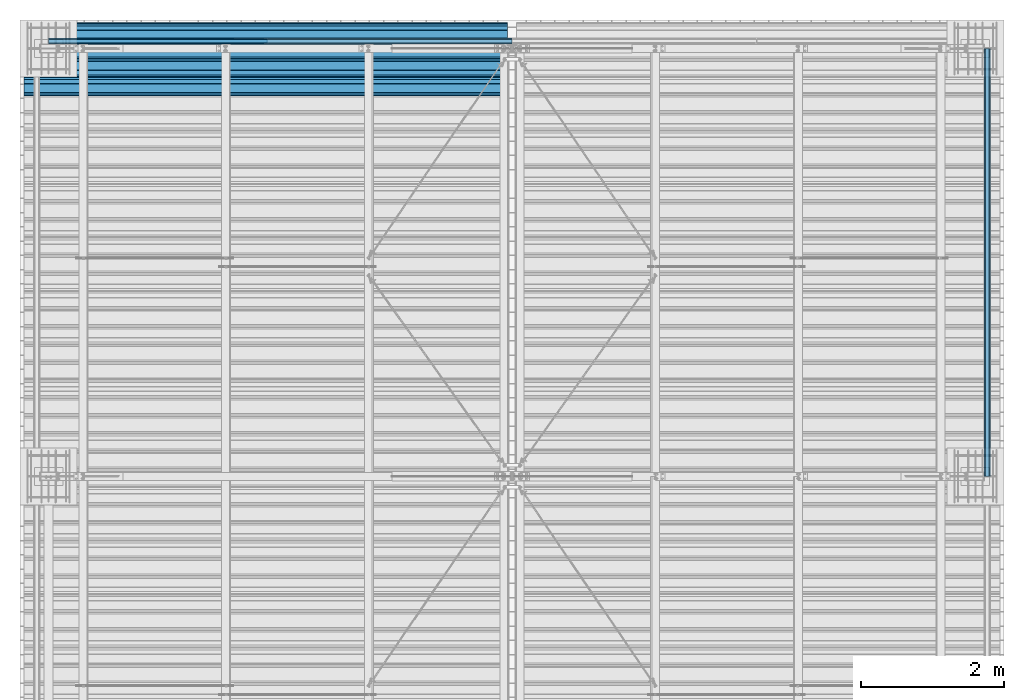
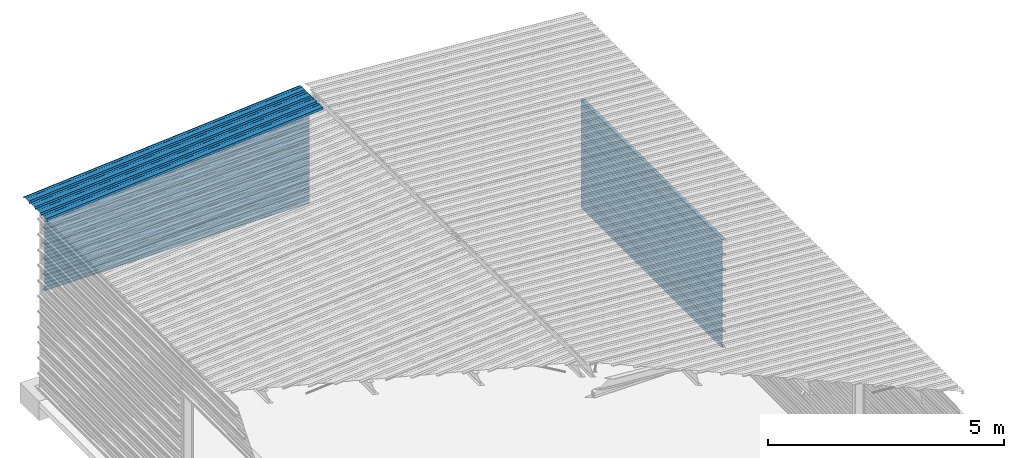
# One storey, part 19 of 70: 14 beams, 14 elements without a shape of their own.
"""IFC2X3 building model written with IfcOpenShell, lengths in millimetres."""

import ifcopenshell
import ifcopenshell.guid

model = None  # the IFC model being written
_history = None  # IfcOwnerHistory: only IFC2X3 demands one
_inside = {}  # id of a spatial element -> (the spatial element, [elements in it])
_under = {}  # id of a project, library or spatial element -> (it, [spatial elements below it])
_declared = {}  # id of a project -> (the project, [libraries it declares])
_typed = {}  # id of a type object -> (the type object, [elements of that type])
_made_of = {}  # id of a material, layer set ... -> (it, [elements and type objects made of it])


def new_model(schema):
    """Start an empty IFC model of exactly this schema.

    Asked for "IFC4X3", IfcOpenShell would pick the latest addendum, in which some entities
    have other attributes; the version numbers below select the first issue.
    IFC2X3 requires an IfcOwnerHistory on every rooted entity: one is made here for all.
    """
    global model, _history
    if schema == "IFC4X3":
        model = ifcopenshell.file(schema_version=(4, 3, 0, 0))
    else:
        model = ifcopenshell.file(schema=schema)
    _inside.clear()
    _under.clear()
    _declared.clear()
    _typed.clear()
    _made_of.clear()
    _history = None
    if model.schema == "IFC2X3":
        org = make("IfcOrganization", Name="unknown")
        user = make(
            "IfcPersonAndOrganization",
            ThePerson=make("IfcPerson", FamilyName="unknown"),
            TheOrganization=org,
        )
        app = make(
            "IfcApplication",
            ApplicationDeveloper=org,
            Version="unknown",
            ApplicationFullName="unknown",
            ApplicationIdentifier="unknown",
        )
        _history = make(
            "IfcOwnerHistory",
            OwningUser=user,
            OwningApplication=app,
            ChangeAction="ADDED",
            CreationDate=0,
        )
    return model


def make(cls, **values):
    """One entity of the class cls with the attributes given. An attribute that is None is left unset."""
    return model.create_entity(
        cls, **{name: value for name, value in values.items() if value is not None}
    )


def rooted(cls, **values):
    """An entity with a GlobalId (a new one), such as an element, a storey or a relation."""
    return make(cls, GlobalId=ifcopenshell.guid.new(), OwnerHistory=_history, **values)


def si_unit(unit_type, name, prefix=None):
    """IfcSIUnit, for example si_unit("LENGTHUNIT", "METRE", prefix="MILLI")."""
    return make("IfcSIUnit", UnitType=unit_type, Prefix=prefix, Name=name)


def assignment(units):
    """IfcUnitAssignment: the units of a project."""
    return None if units is None else make("IfcUnitAssignment", Units=units)


def point(xyz):
    """IfcCartesianPoint."""
    return None if xyz is None else make("IfcCartesianPoint", Coordinates=xyz)


def direction(xyz):
    """IfcDirection."""
    return None if xyz is None else make("IfcDirection", DirectionRatios=xyz)


def frame(location, z_axis=None, x_axis=None):
    """IfcAxis2Placement3D, a coordinate frame: its origin and axes. An axis left out is left unset."""
    return make(
        "IfcAxis2Placement3D",
        Location=point(location),
        Axis=direction(z_axis),
        RefDirection=direction(x_axis),
    )


def origin_with_axes():
    """The frame at (0, 0, 0) with the z axis (0, 0, 1) and the x axis (1, 0, 0) written out."""
    return frame((0.0, 0.0, 0.0), z_axis=(0.0, 0.0, 1.0), x_axis=(1.0, 0.0, 0.0))


def place(relative_to, where):
    """IfcLocalPlacement: puts the frame where relative to a parent placement (None: the world)."""
    return make(
        "IfcLocalPlacement", PlacementRelTo=relative_to, RelativePlacement=where
    )


def context(
    kind, dimensions, precision=None, world=None, true_north=None, identifier=None
):
    """IfcGeometricRepresentationContext, for example the 3D "Model" context."""
    return make(
        "IfcGeometricRepresentationContext",
        ContextIdentifier=identifier,
        ContextType=kind,
        CoordinateSpaceDimension=dimensions,
        Precision=precision,
        WorldCoordinateSystem=world,
        TrueNorth=true_north,
    )


def subcontext(parent, identifier, kind, view, scale=None):
    """IfcGeometricRepresentationSubContext, for example "Body" below "Model"."""
    return make(
        "IfcGeometricRepresentationSubContext",
        ContextIdentifier=identifier,
        ContextType=kind,
        ParentContext=parent,
        TargetScale=scale,
        TargetView=view,
    )


def project(units=None, contexts=None):
    """IfcProject with its units and contexts."""
    return rooted(
        "IfcProject",
        Name="project",
        RepresentationContexts=contexts,
        UnitsInContext=assignment(units),
    )


def spatial(cls, under=None, at=None, **own):
    """A site, building, storey or space (cls), placed at a placement, below another one or the project."""
    s = rooted(cls, ObjectPlacement=at, **own)
    if under is not None:
        _under.setdefault(under.id(), (under, []))[1].append(s)
    return s


def polyline(points):
    """IfcPolyline through the points."""
    return make("IfcPolyline", Points=[point(p) for p in points])


def outline(outer, holes=None, kind="AREA"):
    """IfcArbitraryClosedProfileDef: a profile drawn as a closed curve; with holes, ...WithVoids."""
    if holes is None:
        return make("IfcArbitraryClosedProfileDef", ProfileType=kind, OuterCurve=outer)
    return make(
        "IfcArbitraryProfileDefWithVoids",
        ProfileType=kind,
        OuterCurve=outer,
        InnerCurves=holes,
    )


def extrude(swept, where, along, depth):
    """IfcExtrudedAreaSolid: the profile swept, set in the frame where, extruded along a direction by depth."""
    return make(
        "IfcExtrudedAreaSolid",
        SweptArea=swept,
        Position=where,
        ExtrudedDirection=direction(along),
        Depth=depth,
    )


def clip(a, b, op="DIFFERENCE"):
    """IfcBooleanClippingResult: the solid a cut by the half space b."""
    return make(
        "IfcBooleanClippingResult", Operator=op, FirstOperand=a, SecondOperand=b
    )


def halfspace(plane, agree):
    """IfcHalfSpaceSolid: all space on one side of the plane z = 0 of the frame plane."""
    return make(
        "IfcHalfSpaceSolid",
        BaseSurface=make("IfcPlane", Position=plane),
        AgreementFlag=agree,
    )


def shape(context_of_items, identifier, shape_type, items):
    """IfcShapeRepresentation: the items that make up one representation, for example the "Body"."""
    return make(
        "IfcShapeRepresentation",
        ContextOfItems=context_of_items,
        RepresentationIdentifier=identifier,
        RepresentationType=shape_type,
        Items=items,
    )


def material(Name=None, Category=None):
    """IfcMaterial."""
    return make("IfcMaterial", Name=Name, Category=Category)


def made_of(thing, what):
    """Note that an element or type object is made of a material, layer set ...; save() writes the relation."""
    if what is not None:
        _made_of.setdefault(what.id(), (what, []))[1].append(thing)
    return thing


def type_object(cls, material=None, **own):
    """A type object (cls), such as IfcWallType, which elements share."""
    return made_of(rooted(cls, **own), material)


def element(
    cls,
    number,
    at=None,
    inside=None,
    cuts=None,
    type_object=None,
    material=None,
    context=None,
    identifier="Body",
    shape_type=None,
    held_by="IfcProductDefinitionShape",
    body=None,
    shapes=None,
    **own,
):
    """One element of the class cls, such as IfcWall. Its Tag is "e" and its number.

    at: its placement. inside: the storey or other place that contains it. cuts: it is an
    opening in that element (IfcRelVoidsElement). A single representation is given by context,
    identifier, shape_type and body (its items); several are given by shapes. held_by: the class
    of the entity that holds the representations. save() writes the other relations.
    """
    e = rooted(cls, Tag="e%d" % number, ObjectPlacement=at, **own)
    if body is not None:
        shapes = [shape(context, identifier, shape_type, body)]
    if shapes is not None:
        e.Representation = make(held_by, Representations=shapes)
    if inside is not None:
        _inside.setdefault(inside.id(), (inside, []))[1].append(e)
    if cuts is not None:
        rooted(
            "IfcRelVoidsElement", RelatingBuildingElement=cuts, RelatedOpeningElement=e
        )
    if type_object is not None:
        _typed.setdefault(type_object.id(), (type_object, []))[1].append(e)
    return made_of(e, material)


def aggregate(whole, parts):
    """IfcRelAggregates: a whole, such as a stair, and the parts it consists of."""
    return rooted("IfcRelAggregates", RelatingObject=whole, RelatedObjects=parts)


def save(model, path):
    """Write the relations noted so far, then the file.

    IfcRelAggregates (storeys below a building ...), IfcRelContainedInSpatialStructure (elements
    in a storey), IfcRelDefinesByType, IfcRelAssociatesMaterial and IfcRelDeclares: one each for
    every whole, place, type object, material and project.
    """
    for whole, parts in _under.values():
        aggregate(whole, parts)
    for where, things in _inside.values():
        rooted(
            "IfcRelContainedInSpatialStructure",
            RelatedElements=things,
            RelatingStructure=where,
        )
    for kind, things in _typed.values():
        rooted("IfcRelDefinesByType", RelatedObjects=things, RelatingType=kind)
    for what, things in _made_of.values():
        rooted("IfcRelAssociatesMaterial", RelatedObjects=things, RelatingMaterial=what)
    for by, libraries in _declared.values():
        rooted("IfcRelDeclares", RelatingContext=by, RelatedDefinitions=libraries)
    model.write(path)


model = new_model("IFC2X3")

# Units and contexts
model_context = context("Model", 3, precision=1e-05, world=origin_with_axes())
body_context = subcontext(model_context, "Body", "Model", "MODEL_VIEW")
ifc_project = project(units=[si_unit("LENGTHUNIT", "METRE", prefix="MILLI"), si_unit("AREAUNIT", "SQUARE_METRE"), si_unit("VOLUMEUNIT", "CUBIC_METRE"), si_unit("MASSUNIT", "GRAM", prefix="KILO"), si_unit("TIMEUNIT", "SECOND"), si_unit("PLANEANGLEUNIT", "RADIAN"), si_unit("SOLIDANGLEUNIT", "STERADIAN"), si_unit("THERMODYNAMICTEMPERATUREUNIT", "DEGREE_CELSIUS"), si_unit("LUMINOUSINTENSITYUNIT", "LUMEN")], contexts=[model_context])

# Site, building, storey
site_placement = place(None, origin_with_axes())
site = spatial("IfcSite", under=ifc_project, at=site_placement, CompositionType="ELEMENT")
building_placement = place(site_placement, origin_with_axes())
building = spatial("IfcBuilding", under=site, at=building_placement, Name="Undefined", CompositionType="ELEMENT")
storey_placement = place(building_placement, origin_with_axes())
storey = spatial("IfcBuildingStorey", under=building, at=storey_placement, Name="Undefined", CompositionType="ELEMENT", Elevation=0.0)

# Assembly, beam
assembly_1_placement = place(storey_placement, origin_with_axes())
assembly_1 = element("IfcElementAssembly", 1, at=assembly_1_placement, inside=storey, Name="Steel Assembly", AssemblyPlace="NOTDEFINED", PredefinedType="RIGID_FRAME")
ifc_material = material(Name="STEEL/S235JR")
beam_type_1 = type_object("IfcBeamType", Name="4.40", PredefinedType="NOTDEFINED")
beam_1_placement = place(assembly_1_placement, frame((6436.3924886804, 23850.0, 5336.31760454264), z_axis=(0.0766964990376782, 0.0, -0.997054485489817), x_axis=(-0.997054485489818, 0.0, -0.0766964990376602)))
beam_1 = element("IfcBeam", 2, at=beam_1_placement, type_object=beam_type_1, material=ifc_material, ObjectType="4.40", context=body_context, shape_type="SweptSolid", body=[
    extrude(outline(polyline([(509.415161132813, 19.5000000011705), (490.584838867188, 19.5000000011705), (468.084838867188, -20.4999999988113), (406.585784912109, -20.4999999988113), (404.585784912109, -18.4999999988122), (345.414215087891, -18.4999999988122), (343.414215087891, -20.4999999988113), (281.915161132813, -20.4999999988113), (259.415161132813, 19.5000000011705), (240.584854125977, 19.5000000011705), (218.084854125977, -20.4999999988113), (156.585784912109, -20.4999999988113), (154.585784912109, -18.4999999988122), (95.4142150878906, -18.4999999988122), (93.4142150878906, -20.4999999988113), (31.9151515960693, -20.4999999988113), (9.41515254974365, 19.5000000011705), (-9.41515254974365, 19.5000000011705), (-31.9151515960693, -20.4999999988113), (-93.4142150878906, -20.4999999988113), (-95.4142150878906, -18.4999999988122), (-154.585784912109, -18.4999999988122), (-156.585784912109, -20.4999999988113), (-218.084854125977, -20.4999999988113), (-240.584854125977, 19.5000000011705), (-259.415161132813, 19.5000000011705), (-281.915161132813, -20.4999999988113), (-343.414215087891, -20.4999999988113), (-345.414215087891, -18.4999999988122), (-404.585784912109, -18.4999999988122), (-406.585784912109, -20.4999999988113), (-468.084838867188, -20.4999999988113), (-490.584838867188, 19.5000000011705), (-509.415161132813, 19.5000000011705), (-516.482360839844, 6.9361057293263), (-517.353942871094, 7.42636680720625), (-510.0, 20.5000000011705), (-490.0, 20.5000000011705), (-467.5, -19.4999999988122), (-407.0, -19.4999999988122), (-405.0, -17.4999999988131), (-345.0, -17.4999999988131), (-343.0, -19.4999999988122), (-282.5, -19.4999999988122), (-260.0, 20.5000000011705), (-240.0, 20.5000000011705), (-217.5, -19.4999999988122), (-157.0, -19.4999999988122), (-155.0, -17.4999999988131), (-95.0, -17.4999999988131), (-93.0, -19.4999999988122), (-32.5, -19.4999999988122), (-10.0, 20.5000000011705), (10.0, 20.5000000011705), (32.5, -19.4999999988122), (93.0, -19.4999999988122), (95.0, -17.4999999988131), (155.0, -17.4999999988131), (157.0, -19.4999999988122), (217.5, -19.4999999988122), (240.0, 20.5000000011705), (260.0, 20.5000000011705), (282.5, -19.4999999988122), (343.0, -19.4999999988122), (345.0, -17.4999999988131), (405.0, -17.4999999988131), (407.0, -19.4999999988122), (467.5, -19.4999999988122), (490.0, 20.5000000011705), (510.0, 20.5000000011705), (517.353942871094, 7.42636680720625), (516.482360839844, 6.9361057293263), (509.415161132813, 19.5000000011705)])), frame((6799.99999999733, 2.8421709430404e-14, 0.0), z_axis=(-1.0, 0.0, 0.0), x_axis=(0.0, -1.0, 0.0)), (0.0, 0.0, 1.0), 6800.0),
])
aggregate(assembly_1, [beam_1])

assembly_2_placement = place(storey_placement, origin_with_axes())
assembly_2 = element("IfcElementAssembly", 3, at=assembly_2_placement, inside=storey, Name="Steel Assembly", AssemblyPlace="NOTDEFINED", PredefinedType="RIGID_FRAME")
beam_type_2 = type_object("IfcBeamType", Name="400", PredefinedType="NOTDEFINED")
beam_2_placement = place(assembly_2_placement, frame((0.0, 24105.5035213674, 4618.25), z_axis=(0.0, 1.0, 0.0), x_axis=(1.0, 0.0, 0.0)))
beam_2 = element("IfcBeam", 4, at=beam_2_placement, type_object=beam_type_2, material=ifc_material, ObjectType="400", context=body_context, shape_type="Clipping", body=[
    clip(extrude(outline(polyline([(218.25, -24.994083404541), (214.25, -31.8999996185303), (214.25, -45.5), (199.75, -45.5), (194.25, -42.5), (188.75, -45.5), (124.25, -45.5), (114.25, -41.5), (104.25, -45.5), (24.25, -45.5), (14.25, -41.5), (4.25, -45.5), (-75.75, -45.5), (-85.75, -41.5), (-95.75, -45.5), (-160.25, -45.5), (-165.75, -42.5), (-171.25, -45.5), (-185.75, -45.5), (-185.75, -30.711540222168), (-181.75, -23.8111782073975), (-181.75, 23.311637878418), (-185.75, 30.2119998931885), (-185.75, 44.5), (-217.25, 44.5), (-217.25, 34.7999992370605), (-218.25, 34.7999992370605), (-218.25, 45.5), (-184.75, 45.5), (-184.75, 30.480884552002), (-180.75, 23.5805225372314), (-180.75, -24.0800628662109), (-184.75, -30.9804248809814), (-184.75, -44.5), (-171.504989624023, -44.5), (-165.75, -41.360912322998), (-159.995010375977, -44.5), (-95.9425811767578, -44.5), (-85.75, -40.422966003418), (-75.5574188232422, -44.5), (4.05741739273071, -44.5), (14.25, -40.422966003418), (24.4425830841064, -44.5), (104.057418823242, -44.5), (114.25, -40.422966003418), (124.442581176758, -44.5), (188.495010375977, -44.5), (194.25, -41.360912322998), (200.004989624023, -44.5), (213.25, -44.5), (213.25, -31.6313018798828), (217.25, -24.7253856658936), (217.25, 21.7253856658936), (213.25, 28.6313018798828), (213.25, 42.0), (187.25, 42.0), (187.25, 32.5499992370605), (186.25, 32.5499992370605), (186.25, 43.0), (214.25, 43.0), (214.25, 28.8999996185303), (218.25, 21.994083404541), (218.25, -24.994083404541)])), frame((6500.0, 0.0, 0.0), z_axis=(-1.0, 0.0, 0.0), x_axis=(0.0, -1.0, 0.0)), (0.0, 0.0, 1.0), 6500.0), halfspace(frame((0.0, 18.2500010030071, -45.0), z_axis=(-0.0766964990376778, -0.997054485489817, 0.0), x_axis=(0.0, 0.0, 1.0)), False)),
])
aggregate(assembly_2, [beam_2])

assembly_3_placement = place(storey_placement, origin_with_axes())
assembly_3 = element("IfcElementAssembly", 5, at=assembly_3_placement, inside=storey, Name="Steel Assembly", AssemblyPlace="NOTDEFINED", PredefinedType="RIGID_FRAME")
beam_3_placement = place(assembly_3_placement, frame((0.0, 24105.5035213674, 4218.25), z_axis=(0.0, 1.0, 0.0), x_axis=(1.0, 0.0, 0.0)))
beam_3 = element("IfcBeam", 6, at=beam_3_placement, type_object=beam_type_2, material=ifc_material, ObjectType="400", context=body_context, shape_type="SweptSolid", body=[
    extrude(outline(polyline([(218.25, -24.994083404541), (214.25, -31.8999996185303), (214.25, -45.5), (199.75, -45.5), (194.25, -42.5), (188.75, -45.5), (124.25, -45.5), (114.25, -41.5), (104.25, -45.5), (24.25, -45.5), (14.25, -41.5), (4.25, -45.5), (-75.75, -45.5), (-85.75, -41.5), (-95.75, -45.5), (-160.25, -45.5), (-165.75, -42.5), (-171.25, -45.5), (-185.75, -45.5), (-185.75, -30.711540222168), (-181.75, -23.8111782073975), (-181.75, 23.311637878418), (-185.75, 30.2119998931885), (-185.75, 44.5), (-217.25, 44.5), (-217.25, 34.7999992370605), (-218.25, 34.7999992370605), (-218.25, 45.5), (-184.75, 45.5), (-184.75, 30.480884552002), (-180.75, 23.5805225372314), (-180.75, -24.0800628662109), (-184.75, -30.9804248809814), (-184.75, -44.5), (-171.504989624023, -44.5), (-165.75, -41.360912322998), (-159.995010375977, -44.5), (-95.9425811767578, -44.5), (-85.75, -40.422966003418), (-75.5574188232422, -44.5), (4.05741739273071, -44.5), (14.25, -40.422966003418), (24.4425830841064, -44.5), (104.057418823242, -44.5), (114.25, -40.422966003418), (124.442581176758, -44.5), (188.495010375977, -44.5), (194.25, -41.360912322998), (200.004989624023, -44.5), (213.25, -44.5), (213.25, -31.6313018798828), (217.25, -24.7253856658936), (217.25, 21.7253856658936), (213.25, 28.6313018798828), (213.25, 42.0), (187.25, 42.0), (187.25, 32.5499992370605), (186.25, 32.5499992370605), (186.25, 43.0), (214.25, 43.0), (214.25, 28.8999996185303), (218.25, 21.994083404541), (218.25, -24.994083404541)])), frame((6500.0, 0.0, 0.0), z_axis=(-1.0, 0.0, 0.0), x_axis=(0.0, -1.0, 0.0)), (0.0, 0.0, 1.0), 6500.0),
])
aggregate(assembly_3, [beam_3])

assembly_4_placement = place(storey_placement, origin_with_axes())
assembly_4 = element("IfcElementAssembly", 7, at=assembly_4_placement, inside=storey, Name="Steel Assembly", AssemblyPlace="NOTDEFINED", PredefinedType="RIGID_FRAME")
beam_4_placement = place(assembly_4_placement, frame((0.0, 24105.5035213674, 3818.25), z_axis=(0.0, 1.0, 0.0), x_axis=(1.0, 0.0, 0.0)))
beam_4 = element("IfcBeam", 8, at=beam_4_placement, type_object=beam_type_2, material=ifc_material, ObjectType="400", context=body_context, shape_type="SweptSolid", body=[
    extrude(outline(polyline([(218.25, -24.994083404541), (214.25, -31.8999996185303), (214.25, -45.5), (199.75, -45.5), (194.25, -42.5), (188.75, -45.5), (124.25, -45.5), (114.25, -41.5), (104.25, -45.5), (24.25, -45.5), (14.25, -41.5), (4.25, -45.5), (-75.75, -45.5), (-85.75, -41.5), (-95.75, -45.5), (-160.25, -45.5), (-165.75, -42.5), (-171.25, -45.5), (-185.75, -45.5), (-185.75, -30.711540222168), (-181.75, -23.8111782073975), (-181.75, 23.311637878418), (-185.75, 30.2119998931885), (-185.75, 44.5), (-217.25, 44.5), (-217.25, 34.7999992370605), (-218.25, 34.7999992370605), (-218.25, 45.5), (-184.75, 45.5), (-184.75, 30.480884552002), (-180.75, 23.5805225372314), (-180.75, -24.0800628662109), (-184.75, -30.9804248809814), (-184.75, -44.5), (-171.504989624023, -44.5), (-165.75, -41.360912322998), (-159.995010375977, -44.5), (-95.9425811767578, -44.5), (-85.75, -40.422966003418), (-75.5574188232422, -44.5), (4.05741739273071, -44.5), (14.25, -40.422966003418), (24.4425830841064, -44.5), (104.057418823242, -44.5), (114.25, -40.422966003418), (124.442581176758, -44.5), (188.495010375977, -44.5), (194.25, -41.360912322998), (200.004989624023, -44.5), (213.25, -44.5), (213.25, -31.6313018798828), (217.25, -24.7253856658936), (217.25, 21.7253856658936), (213.25, 28.6313018798828), (213.25, 42.0), (187.25, 42.0), (187.25, 32.5499992370605), (186.25, 32.5499992370605), (186.25, 43.0), (214.25, 43.0), (214.25, 28.8999996185303), (218.25, 21.994083404541), (218.25, -24.994083404541)])), frame((6500.0, 0.0, 0.0), z_axis=(-1.0, 0.0, 0.0), x_axis=(0.0, -1.0, 0.0)), (0.0, 0.0, 1.0), 6500.0),
])
aggregate(assembly_4, [beam_4])

assembly_5_placement = place(storey_placement, origin_with_axes())
assembly_5 = element("IfcElementAssembly", 9, at=assembly_5_placement, inside=storey, Name="Steel Assembly", AssemblyPlace="NOTDEFINED", PredefinedType="RIGID_FRAME")
beam_5_placement = place(assembly_5_placement, frame((0.0, 24105.5035213674, 3418.25), z_axis=(0.0, 1.0, 0.0), x_axis=(1.0, 0.0, 0.0)))
beam_5 = element("IfcBeam", 10, at=beam_5_placement, type_object=beam_type_2, material=ifc_material, ObjectType="400", context=body_context, shape_type="SweptSolid", body=[
    extrude(outline(polyline([(218.25, -24.994083404541), (214.25, -31.8999996185303), (214.25, -45.5), (199.75, -45.5), (194.25, -42.5), (188.75, -45.5), (124.25, -45.5), (114.25, -41.5), (104.25, -45.5), (24.25, -45.5), (14.25, -41.5), (4.25, -45.5), (-75.75, -45.5), (-85.75, -41.5), (-95.75, -45.5), (-160.25, -45.5), (-165.75, -42.5), (-171.25, -45.5), (-185.75, -45.5), (-185.75, -30.711540222168), (-181.75, -23.8111782073975), (-181.75, 23.311637878418), (-185.75, 30.2119998931885), (-185.75, 44.5), (-217.25, 44.5), (-217.25, 34.7999992370605), (-218.25, 34.7999992370605), (-218.25, 45.5), (-184.75, 45.5), (-184.75, 30.480884552002), (-180.75, 23.5805225372314), (-180.75, -24.0800628662109), (-184.75, -30.9804248809814), (-184.75, -44.5), (-171.504989624023, -44.5), (-165.75, -41.360912322998), (-159.995010375977, -44.5), (-95.9425811767578, -44.5), (-85.75, -40.422966003418), (-75.5574188232422, -44.5), (4.05741739273071, -44.5), (14.25, -40.422966003418), (24.4425830841064, -44.5), (104.057418823242, -44.5), (114.25, -40.422966003418), (124.442581176758, -44.5), (188.495010375977, -44.5), (194.25, -41.360912322998), (200.004989624023, -44.5), (213.25, -44.5), (213.25, -31.6313018798828), (217.25, -24.7253856658936), (217.25, 21.7253856658936), (213.25, 28.6313018798828), (213.25, 42.0), (187.25, 42.0), (187.25, 32.5499992370605), (186.25, 32.5499992370605), (186.25, 43.0), (214.25, 43.0), (214.25, 28.8999996185303), (218.25, 21.994083404541), (218.25, -24.994083404541)])), frame((6500.0, 0.0, 0.0), z_axis=(-1.0, 0.0, 0.0), x_axis=(0.0, -1.0, 0.0)), (0.0, 0.0, 1.0), 6500.0),
])
aggregate(assembly_5, [beam_5])

assembly_6_placement = place(storey_placement, origin_with_axes())
assembly_6 = element("IfcElementAssembly", 11, at=assembly_6_placement, inside=storey, Name="Steel Assembly", AssemblyPlace="NOTDEFINED", PredefinedType="RIGID_FRAME")
beam_6_placement = place(assembly_6_placement, frame((0.0, 24105.5035213674, 3018.25), z_axis=(0.0, 1.0, 0.0), x_axis=(1.0, 0.0, 0.0)))
beam_6 = element("IfcBeam", 12, at=beam_6_placement, type_object=beam_type_2, material=ifc_material, ObjectType="400", context=body_context, shape_type="SweptSolid", body=[
    extrude(outline(polyline([(218.25, -24.994083404541), (214.25, -31.8999996185303), (214.25, -45.5), (199.75, -45.5), (194.25, -42.5), (188.75, -45.5), (124.25, -45.5), (114.25, -41.5), (104.25, -45.5), (24.25, -45.5), (14.25, -41.5), (4.25, -45.5), (-75.75, -45.5), (-85.75, -41.5), (-95.75, -45.5), (-160.25, -45.5), (-165.75, -42.5), (-171.25, -45.5), (-185.75, -45.5), (-185.75, -30.711540222168), (-181.75, -23.8111782073975), (-181.75, 23.311637878418), (-185.75, 30.2119998931885), (-185.75, 44.5), (-217.25, 44.5), (-217.25, 34.7999992370605), (-218.25, 34.7999992370605), (-218.25, 45.5), (-184.75, 45.5), (-184.75, 30.480884552002), (-180.75, 23.5805225372314), (-180.75, -24.0800628662109), (-184.75, -30.9804248809814), (-184.75, -44.5), (-171.504989624023, -44.5), (-165.75, -41.360912322998), (-159.995010375977, -44.5), (-95.9425811767578, -44.5), (-85.75, -40.422966003418), (-75.5574188232422, -44.5), (4.05741739273071, -44.5), (14.25, -40.422966003418), (24.4425830841064, -44.5), (104.057418823242, -44.5), (114.25, -40.422966003418), (124.442581176758, -44.5), (188.495010375977, -44.5), (194.25, -41.360912322998), (200.004989624023, -44.5), (213.25, -44.5), (213.25, -31.6313018798828), (217.25, -24.7253856658936), (217.25, 21.7253856658936), (213.25, 28.6313018798828), (213.25, 42.0), (187.25, 42.0), (187.25, 32.5499992370605), (186.25, 32.5499992370605), (186.25, 43.0), (214.25, 43.0), (214.25, 28.8999996185303), (218.25, 21.994083404541), (218.25, -24.994083404541)])), frame((6500.0, 0.0, 0.0), z_axis=(-1.0, 0.0, 0.0), x_axis=(0.0, -1.0, 0.0)), (0.0, 0.0, 1.0), 6500.0),
])
aggregate(assembly_6, [beam_6])

assembly_7_placement = place(storey_placement, origin_with_axes())
assembly_7 = element("IfcElementAssembly", 13, at=assembly_7_placement, inside=storey, Name="Steel Assembly", AssemblyPlace="NOTDEFINED", PredefinedType="RIGID_FRAME")
beam_7_placement = place(assembly_7_placement, frame((0.0, 24105.5035213674, 2618.25), z_axis=(0.0, 1.0, 0.0), x_axis=(1.0, 0.0, 0.0)))
beam_7 = element("IfcBeam", 14, at=beam_7_placement, type_object=beam_type_2, material=ifc_material, ObjectType="400", context=body_context, shape_type="SweptSolid", body=[
    extrude(outline(polyline([(218.25, -24.994083404541), (214.25, -31.8999996185303), (214.25, -45.5), (199.75, -45.5), (194.25, -42.5), (188.75, -45.5), (124.25, -45.5), (114.25, -41.5), (104.25, -45.5), (24.25, -45.5), (14.25, -41.5), (4.25, -45.5), (-75.75, -45.5), (-85.75, -41.5), (-95.75, -45.5), (-160.25, -45.5), (-165.75, -42.5), (-171.25, -45.5), (-185.75, -45.5), (-185.75, -30.711540222168), (-181.75, -23.8111782073975), (-181.75, 23.311637878418), (-185.75, 30.2119998931885), (-185.75, 44.5), (-217.25, 44.5), (-217.25, 34.7999992370605), (-218.25, 34.7999992370605), (-218.25, 45.5), (-184.75, 45.5), (-184.75, 30.480884552002), (-180.75, 23.5805225372314), (-180.75, -24.0800628662109), (-184.75, -30.9804248809814), (-184.75, -44.5), (-171.504989624023, -44.5), (-165.75, -41.360912322998), (-159.995010375977, -44.5), (-95.9425811767578, -44.5), (-85.75, -40.422966003418), (-75.5574188232422, -44.5), (4.05741739273071, -44.5), (14.25, -40.422966003418), (24.4425830841064, -44.5), (104.057418823242, -44.5), (114.25, -40.422966003418), (124.442581176758, -44.5), (188.495010375977, -44.5), (194.25, -41.360912322998), (200.004989624023, -44.5), (213.25, -44.5), (213.25, -31.6313018798828), (217.25, -24.7253856658936), (217.25, 21.7253856658936), (213.25, 28.6313018798828), (213.25, 42.0), (187.25, 42.0), (187.25, 32.5499992370605), (186.25, 32.5499992370605), (186.25, 43.0), (214.25, 43.0), (214.25, 28.8999996185303), (218.25, 21.994083404541), (218.25, -24.994083404541)])), frame((6500.0, 0.0, 0.0), z_axis=(-1.0, 0.0, 0.0), x_axis=(0.0, -1.0, 0.0)), (0.0, 0.0, 1.0), 6500.0),
])
aggregate(assembly_7, [beam_7])

assembly_8_placement = place(storey_placement, origin_with_axes())
assembly_8 = element("IfcElementAssembly", 15, at=assembly_8_placement, inside=storey, Name="Steel Assembly", AssemblyPlace="NOTDEFINED", PredefinedType="RIGID_FRAME")
beam_8_placement = place(assembly_8_placement, frame((13165.4999999991, 24000.0, 2618.17396601053), z_axis=(1.0, 0.0, 0.0), x_axis=(0.0, -1.0, 0.0)))
beam_8 = element("IfcBeam", 16, at=beam_8_placement, type_object=beam_type_2, material=ifc_material, ObjectType="400", context=body_context, shape_type="SweptSolid", body=[
    extrude(outline(polyline([(218.25, -24.994083404541), (214.25, -31.8999996185303), (214.25, -45.5), (199.75, -45.5), (194.25, -42.5), (188.75, -45.5), (124.25, -45.5), (114.25, -41.5), (104.25, -45.5), (24.25, -45.5), (14.25, -41.5), (4.25, -45.5), (-75.75, -45.5), (-85.75, -41.5), (-95.75, -45.5), (-160.25, -45.5), (-165.75, -42.5), (-171.25, -45.5), (-185.75, -45.5), (-185.75, -30.711540222168), (-181.75, -23.8111782073975), (-181.75, 23.311637878418), (-185.75, 30.2119998931885), (-185.75, 44.5), (-217.25, 44.5), (-217.25, 34.7999992370605), (-218.25, 34.7999992370605), (-218.25, 45.5), (-184.75, 45.5), (-184.75, 30.480884552002), (-180.75, 23.5805225372314), (-180.75, -24.0800628662109), (-184.75, -30.9804248809814), (-184.75, -44.5), (-171.504989624023, -44.5), (-165.75, -41.360912322998), (-159.995010375977, -44.5), (-95.9425811767578, -44.5), (-85.75, -40.422966003418), (-75.5574188232422, -44.5), (4.05741739273071, -44.5), (14.25, -40.422966003418), (24.4425830841064, -44.5), (104.057418823242, -44.5), (114.25, -40.422966003418), (124.442581176758, -44.5), (188.495010375977, -44.5), (194.25, -41.360912322998), (200.004989624023, -44.5), (213.25, -44.5), (213.25, -31.6313018798828), (217.25, -24.7253856658936), (217.25, 21.7253856658936), (213.25, 28.6313018798828), (213.25, 42.0), (187.25, 42.0), (187.25, 32.5499992370605), (186.25, 32.5499992370605), (186.25, 43.0), (214.25, 43.0), (214.25, 28.8999996185303), (218.25, 21.994083404541), (218.25, -24.994083404541)])), frame((6000.0, 0.0, 0.0), z_axis=(-1.0, 0.0, 0.0), x_axis=(0.0, -1.0, 0.0)), (0.0, 0.0, 1.0), 6000.0),
])
aggregate(assembly_8, [beam_8])

assembly_9_placement = place(storey_placement, origin_with_axes())
assembly_9 = element("IfcElementAssembly", 17, at=assembly_9_placement, inside=storey, Name="Steel Assembly", AssemblyPlace="NOTDEFINED", PredefinedType="RIGID_FRAME")
beam_9_placement = place(assembly_9_placement, frame((13165.4999999992, 24000.0, 2218.17396601053), z_axis=(1.0, 0.0, 0.0), x_axis=(0.0, -1.0, 0.0)))
beam_9 = element("IfcBeam", 18, at=beam_9_placement, type_object=beam_type_2, material=ifc_material, ObjectType="400", context=body_context, shape_type="SweptSolid", body=[
    extrude(outline(polyline([(218.25, -24.994083404541), (214.25, -31.8999996185303), (214.25, -45.5), (199.75, -45.5), (194.25, -42.5), (188.75, -45.5), (124.25, -45.5), (114.25, -41.5), (104.25, -45.5), (24.25, -45.5), (14.25, -41.5), (4.25, -45.5), (-75.75, -45.5), (-85.75, -41.5), (-95.75, -45.5), (-160.25, -45.5), (-165.75, -42.5), (-171.25, -45.5), (-185.75, -45.5), (-185.75, -30.711540222168), (-181.75, -23.8111782073975), (-181.75, 23.311637878418), (-185.75, 30.2119998931885), (-185.75, 44.5), (-217.25, 44.5), (-217.25, 34.7999992370605), (-218.25, 34.7999992370605), (-218.25, 45.5), (-184.75, 45.5), (-184.75, 30.480884552002), (-180.75, 23.5805225372314), (-180.75, -24.0800628662109), (-184.75, -30.9804248809814), (-184.75, -44.5), (-171.504989624023, -44.5), (-165.75, -41.360912322998), (-159.995010375977, -44.5), (-95.9425811767578, -44.5), (-85.75, -40.422966003418), (-75.5574188232422, -44.5), (4.05741739273071, -44.5), (14.25, -40.422966003418), (24.4425830841064, -44.5), (104.057418823242, -44.5), (114.25, -40.422966003418), (124.442581176758, -44.5), (188.495010375977, -44.5), (194.25, -41.360912322998), (200.004989624023, -44.5), (213.25, -44.5), (213.25, -31.6313018798828), (217.25, -24.7253856658936), (217.25, 21.7253856658936), (213.25, 28.6313018798828), (213.25, 42.0), (187.25, 42.0), (187.25, 32.5499992370605), (186.25, 32.5499992370605), (186.25, 43.0), (214.25, 43.0), (214.25, 28.8999996185303), (218.25, 21.994083404541), (218.25, -24.994083404541)])), frame((6000.0, 0.0, 0.0), z_axis=(-1.0, 0.0, 0.0), x_axis=(0.0, -1.0, 0.0)), (0.0, 0.0, 1.0), 6000.0),
])
aggregate(assembly_9, [beam_9])

assembly_10_placement = place(storey_placement, origin_with_axes())
assembly_10 = element("IfcElementAssembly", 19, at=assembly_10_placement, inside=storey, Name="Steel Assembly", AssemblyPlace="NOTDEFINED", PredefinedType="RIGID_FRAME")
beam_10_placement = place(assembly_10_placement, frame((13165.4999999994, 24000.0, 1818.17396601053), z_axis=(1.0, 0.0, 0.0), x_axis=(0.0, -1.0, 0.0)))
beam_10 = element("IfcBeam", 20, at=beam_10_placement, type_object=beam_type_2, material=ifc_material, ObjectType="400", context=body_context, shape_type="SweptSolid", body=[
    extrude(outline(polyline([(218.25, -24.994083404541), (214.25, -31.8999996185303), (214.25, -45.5), (199.75, -45.5), (194.25, -42.5), (188.75, -45.5), (124.25, -45.5), (114.25, -41.5), (104.25, -45.5), (24.25, -45.5), (14.25, -41.5), (4.25, -45.5), (-75.75, -45.5), (-85.75, -41.5), (-95.75, -45.5), (-160.25, -45.5), (-165.75, -42.5), (-171.25, -45.5), (-185.75, -45.5), (-185.75, -30.711540222168), (-181.75, -23.8111782073975), (-181.75, 23.311637878418), (-185.75, 30.2119998931885), (-185.75, 44.5), (-217.25, 44.5), (-217.25, 34.7999992370605), (-218.25, 34.7999992370605), (-218.25, 45.5), (-184.75, 45.5), (-184.75, 30.480884552002), (-180.75, 23.5805225372314), (-180.75, -24.0800628662109), (-184.75, -30.9804248809814), (-184.75, -44.5), (-171.504989624023, -44.5), (-165.75, -41.360912322998), (-159.995010375977, -44.5), (-95.9425811767578, -44.5), (-85.75, -40.422966003418), (-75.5574188232422, -44.5), (4.05741739273071, -44.5), (14.25, -40.422966003418), (24.4425830841064, -44.5), (104.057418823242, -44.5), (114.25, -40.422966003418), (124.442581176758, -44.5), (188.495010375977, -44.5), (194.25, -41.360912322998), (200.004989624023, -44.5), (213.25, -44.5), (213.25, -31.6313018798828), (217.25, -24.7253856658936), (217.25, 21.7253856658936), (213.25, 28.6313018798828), (213.25, 42.0), (187.25, 42.0), (187.25, 32.5499992370605), (186.25, 32.5499992370605), (186.25, 43.0), (214.25, 43.0), (214.25, 28.8999996185303), (218.25, 21.994083404541), (218.25, -24.994083404541)])), frame((6000.0, 0.0, 0.0), z_axis=(-1.0, 0.0, 0.0), x_axis=(0.0, -1.0, 0.0)), (0.0, 0.0, 1.0), 6000.0),
])
aggregate(assembly_10, [beam_10])

assembly_11_placement = place(storey_placement, origin_with_axes())
assembly_11 = element("IfcElementAssembly", 21, at=assembly_11_placement, inside=storey, Name="Steel Assembly", AssemblyPlace="NOTDEFINED", PredefinedType="RIGID_FRAME")
beam_11_placement = place(assembly_11_placement, frame((13165.4999999995, 24000.0, 1418.17396601053), z_axis=(1.0, 0.0, 0.0), x_axis=(0.0, -1.0, 0.0)))
beam_11 = element("IfcBeam", 22, at=beam_11_placement, type_object=beam_type_2, material=ifc_material, ObjectType="400", context=body_context, shape_type="SweptSolid", body=[
    extrude(outline(polyline([(218.25, -24.994083404541), (214.25, -31.8999996185303), (214.25, -45.5), (199.75, -45.5), (194.25, -42.5), (188.75, -45.5), (124.25, -45.5), (114.25, -41.5), (104.25, -45.5), (24.25, -45.5), (14.25, -41.5), (4.25, -45.5), (-75.75, -45.5), (-85.75, -41.5), (-95.75, -45.5), (-160.25, -45.5), (-165.75, -42.5), (-171.25, -45.5), (-185.75, -45.5), (-185.75, -30.711540222168), (-181.75, -23.8111782073975), (-181.75, 23.311637878418), (-185.75, 30.2119998931885), (-185.75, 44.5), (-217.25, 44.5), (-217.25, 34.7999992370605), (-218.25, 34.7999992370605), (-218.25, 45.5), (-184.75, 45.5), (-184.75, 30.480884552002), (-180.75, 23.5805225372314), (-180.75, -24.0800628662109), (-184.75, -30.9804248809814), (-184.75, -44.5), (-171.504989624023, -44.5), (-165.75, -41.360912322998), (-159.995010375977, -44.5), (-95.9425811767578, -44.5), (-85.75, -40.422966003418), (-75.5574188232422, -44.5), (4.05741739273071, -44.5), (14.25, -40.422966003418), (24.4425830841064, -44.5), (104.057418823242, -44.5), (114.25, -40.422966003418), (124.442581176758, -44.5), (188.495010375977, -44.5), (194.25, -41.360912322998), (200.004989624023, -44.5), (213.25, -44.5), (213.25, -31.6313018798828), (217.25, -24.7253856658936), (217.25, 21.7253856658936), (213.25, 28.6313018798828), (213.25, 42.0), (187.25, 42.0), (187.25, 32.5499992370605), (186.25, 32.5499992370605), (186.25, 43.0), (214.25, 43.0), (214.25, 28.8999996185303), (218.25, 21.994083404541), (218.25, -24.994083404541)])), frame((6000.0, 0.0, 0.0), z_axis=(-1.0, 0.0, 0.0), x_axis=(0.0, -1.0, 0.0)), (0.0, 0.0, 1.0), 6000.0),
])
aggregate(assembly_11, [beam_11])

assembly_12_placement = place(storey_placement, origin_with_axes())
assembly_12 = element("IfcElementAssembly", 23, at=assembly_12_placement, inside=storey, Name="Steel Assembly", AssemblyPlace="NOTDEFINED", PredefinedType="RIGID_FRAME")
beam_12_placement = place(assembly_12_placement, frame((13165.4999999997, 24000.0, 1018.17396601053), z_axis=(1.0, 0.0, 0.0), x_axis=(0.0, -1.0, 0.0)))
beam_12 = element("IfcBeam", 24, at=beam_12_placement, type_object=beam_type_2, material=ifc_material, ObjectType="400", context=body_context, shape_type="SweptSolid", body=[
    extrude(outline(polyline([(218.25, -24.994083404541), (214.25, -31.8999996185303), (214.25, -45.5), (199.75, -45.5), (194.25, -42.5), (188.75, -45.5), (124.25, -45.5), (114.25, -41.5), (104.25, -45.5), (24.25, -45.5), (14.25, -41.5), (4.25, -45.5), (-75.75, -45.5), (-85.75, -41.5), (-95.75, -45.5), (-160.25, -45.5), (-165.75, -42.5), (-171.25, -45.5), (-185.75, -45.5), (-185.75, -30.711540222168), (-181.75, -23.8111782073975), (-181.75, 23.311637878418), (-185.75, 30.2119998931885), (-185.75, 44.5), (-217.25, 44.5), (-217.25, 34.7999992370605), (-218.25, 34.7999992370605), (-218.25, 45.5), (-184.75, 45.5), (-184.75, 30.480884552002), (-180.75, 23.5805225372314), (-180.75, -24.0800628662109), (-184.75, -30.9804248809814), (-184.75, -44.5), (-171.504989624023, -44.5), (-165.75, -41.360912322998), (-159.995010375977, -44.5), (-95.9425811767578, -44.5), (-85.75, -40.422966003418), (-75.5574188232422, -44.5), (4.05741739273071, -44.5), (14.25, -40.422966003418), (24.4425830841064, -44.5), (104.057418823242, -44.5), (114.25, -40.422966003418), (124.442581176758, -44.5), (188.495010375977, -44.5), (194.25, -41.360912322998), (200.004989624023, -44.5), (213.25, -44.5), (213.25, -31.6313018798828), (217.25, -24.7253856658936), (217.25, 21.7253856658936), (213.25, 28.6313018798828), (213.25, 42.0), (187.25, 42.0), (187.25, 32.5499992370605), (186.25, 32.5499992370605), (186.25, 43.0), (214.25, 43.0), (214.25, 28.8999996185303), (218.25, 21.994083404541), (218.25, -24.994083404541)])), frame((6000.0, 0.0, 0.0), z_axis=(-1.0, 0.0, 0.0), x_axis=(0.0, -1.0, 0.0)), (0.0, 0.0, 1.0), 6000.0),
])
aggregate(assembly_12, [beam_12])

assembly_13_placement = place(storey_placement, origin_with_axes())
assembly_13 = element("IfcElementAssembly", 25, at=assembly_13_placement, inside=storey, Name="Steel Assembly", AssemblyPlace="NOTDEFINED", PredefinedType="RIGID_FRAME")
beam_13_placement = place(assembly_13_placement, frame((13165.4999999998, 24000.0, 618.173966010529), z_axis=(1.0, 0.0, 0.0), x_axis=(0.0, -1.0, 0.0)))
beam_13 = element("IfcBeam", 26, at=beam_13_placement, type_object=beam_type_2, material=ifc_material, ObjectType="400", context=body_context, shape_type="SweptSolid", body=[
    extrude(outline(polyline([(218.25, -24.994083404541), (214.25, -31.8999996185303), (214.25, -45.5), (199.75, -45.5), (194.25, -42.5), (188.75, -45.5), (124.25, -45.5), (114.25, -41.5), (104.25, -45.5), (24.25, -45.5), (14.25, -41.5), (4.25, -45.5), (-75.75, -45.5), (-85.75, -41.5), (-95.75, -45.5), (-160.25, -45.5), (-165.75, -42.5), (-171.25, -45.5), (-185.75, -45.5), (-185.75, -30.711540222168), (-181.75, -23.8111782073975), (-181.75, 23.311637878418), (-185.75, 30.2119998931885), (-185.75, 44.5), (-217.25, 44.5), (-217.25, 34.7999992370605), (-218.25, 34.7999992370605), (-218.25, 45.5), (-184.75, 45.5), (-184.75, 30.480884552002), (-180.75, 23.5805225372314), (-180.75, -24.0800628662109), (-184.75, -30.9804248809814), (-184.75, -44.5), (-171.504989624023, -44.5), (-165.75, -41.360912322998), (-159.995010375977, -44.5), (-95.9425811767578, -44.5), (-85.75, -40.422966003418), (-75.5574188232422, -44.5), (4.05741739273071, -44.5), (14.25, -40.422966003418), (24.4425830841064, -44.5), (104.057418823242, -44.5), (114.25, -40.422966003418), (124.442581176758, -44.5), (188.495010375977, -44.5), (194.25, -41.360912322998), (200.004989624023, -44.5), (213.25, -44.5), (213.25, -31.6313018798828), (217.25, -24.7253856658936), (217.25, 21.7253856658936), (213.25, 28.6313018798828), (213.25, 42.0), (187.25, 42.0), (187.25, 32.5499992370605), (186.25, 32.5499992370605), (186.25, 43.0), (214.25, 43.0), (214.25, 28.8999996185303), (218.25, 21.994083404541), (218.25, -24.994083404541)])), frame((6000.0, 0.0, 0.0), z_axis=(-1.0, 0.0, 0.0), x_axis=(0.0, -1.0, 0.0)), (0.0, 0.0, 1.0), 6000.0),
])
aggregate(assembly_13, [beam_13])

assembly_14_placement = place(storey_placement, origin_with_axes())
assembly_14 = element("IfcElementAssembly", 27, at=assembly_14_placement, inside=storey, Name="Steel Assembly", AssemblyPlace="NOTDEFINED", PredefinedType="RIGID_FRAME")
beam_14_placement = place(assembly_14_placement, frame((13165.5, 24000.0, 218.173966010529), z_axis=(1.0, 0.0, 0.0), x_axis=(0.0, -1.0, 0.0)))
beam_14 = element("IfcBeam", 28, at=beam_14_placement, type_object=beam_type_2, material=ifc_material, ObjectType="400", context=body_context, shape_type="SweptSolid", body=[
    extrude(outline(polyline([(218.25, -24.994083404541), (214.25, -31.8999996185303), (214.25, -45.5), (199.75, -45.5), (194.25, -42.5), (188.75, -45.5), (124.25, -45.5), (114.25, -41.5), (104.25, -45.5), (24.25, -45.5), (14.25, -41.5), (4.25, -45.5), (-75.75, -45.5), (-85.75, -41.5), (-95.75, -45.5), (-160.25, -45.5), (-165.75, -42.5), (-171.25, -45.5), (-185.75, -45.5), (-185.75, -30.711540222168), (-181.75, -23.8111782073975), (-181.75, 23.311637878418), (-185.75, 30.2119998931885), (-185.75, 44.5), (-217.25, 44.5), (-217.25, 34.7999992370605), (-218.25, 34.7999992370605), (-218.25, 45.5), (-184.75, 45.5), (-184.75, 30.480884552002), (-180.75, 23.5805225372314), (-180.75, -24.0800628662109), (-184.75, -30.9804248809814), (-184.75, -44.5), (-171.504989624023, -44.5), (-165.75, -41.360912322998), (-159.995010375977, -44.5), (-95.9425811767578, -44.5), (-85.75, -40.422966003418), (-75.5574188232422, -44.5), (4.05741739273071, -44.5), (14.25, -40.422966003418), (24.4425830841064, -44.5), (104.057418823242, -44.5), (114.25, -40.422966003418), (124.442581176758, -44.5), (188.495010375977, -44.5), (194.25, -41.360912322998), (200.004989624023, -44.5), (213.25, -44.5), (213.25, -31.6313018798828), (217.25, -24.7253856658936), (217.25, 21.7253856658936), (213.25, 28.6313018798828), (213.25, 42.0), (187.25, 42.0), (187.25, 32.5499992370605), (186.25, 32.5499992370605), (186.25, 43.0), (214.25, 43.0), (214.25, 28.8999996185303), (218.25, 21.994083404541), (218.25, -24.994083404541)])), frame((6000.0, 0.0, 0.0), z_axis=(-1.0, 0.0, 0.0), x_axis=(0.0, -1.0, 0.0)), (0.0, 0.0, 1.0), 6000.0),
])
aggregate(assembly_14, [beam_14])

save(model, "model.ifc")
